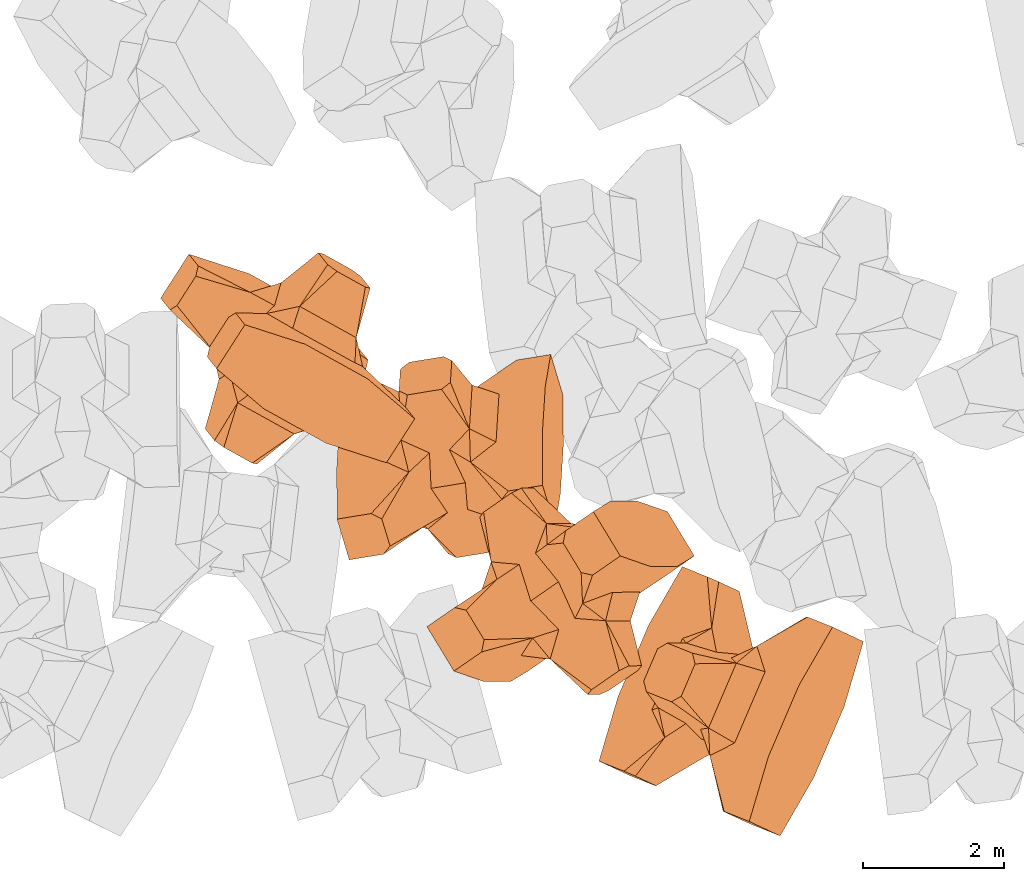
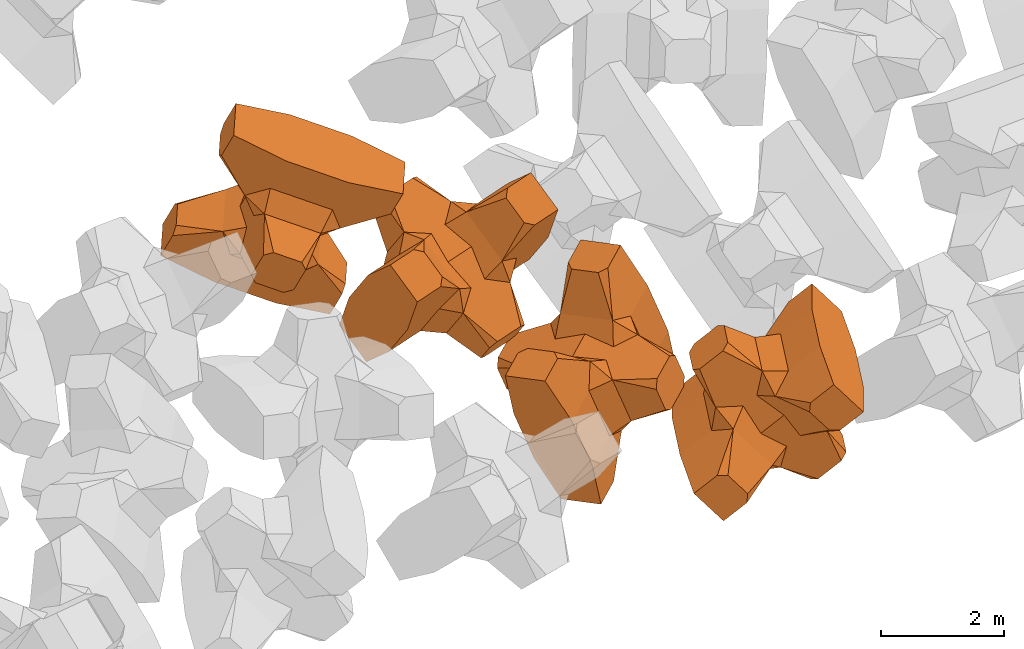
# One storey, part 3 of 17: 4 civil elements.
"""IFC4 building model written with IfcOpenShell, lengths in metres."""

from ifc_helpers import new_model, entity, si_unit, converted_unit, frame, origin_with_axes, origin_2d_with_axis, place, context, subcontext, project, spatial, polygons, element, save


model = new_model("IFC4")

# Units and contexts
model_context = context("Model", 3, precision=1e-05, world=origin_with_axes())
plan_context = context("Plan", 2, precision=1e-05, world=origin_2d_with_axis())
body_context = subcontext(model_context, "Body", "Model", "MODEL_VIEW")
ifc_project = project(units=[si_unit("VOLUMEUNIT", "CUBIC_METRE"), si_unit("LENGTHUNIT", "METRE"), converted_unit("PLANEANGLEUNIT", "degree", entity("IfcReal", 0.0174532925199433), si_unit("PLANEANGLEUNIT", "RADIAN"), dimensions=[0, 0, 0, 0, 0, 0, 0]), si_unit("AREAUNIT", "SQUARE_METRE")], contexts=[model_context, plan_context])

# Site, building, storey
site_placement = place(None, origin_with_axes())
site = spatial("IfcSite", under=ifc_project, at=site_placement)
building_placement = place(site_placement, origin_with_axes())
building = spatial("IfcBuilding", under=site, at=building_placement, Name="Building")
storey_placement = place(building_placement, origin_with_axes())
storey = spatial("IfcBuildingStorey", under=building, at=storey_placement, Name="Storey")

# Civil elements
civil_element_1_placement = place(storey_placement, frame((15.2045488357544, -20.4783554077148, 2.44724321365356), z_axis=(0.583704947890103, -0.272912025201431, -0.764727114929937), x_axis=(0.393692462776794, 0.918833492180181, -0.027409093394634)))
element("IfcCivilElement", 1, at=civil_element_1_placement, inside=storey, ObjectType="IfcCivilElementType", context=body_context, shape_type="Tessellation", body=[
    polygons([(0.500000178813934, 0.500000059604645, 0.821428716182709), (0.374999850988388, 0.249999940395355, 1.50000023841858), (0.550000071525574, 0.145680621266365, 0.550000131130219), (0.374999850988388, -0.250000029802322, 1.50000023841858), (0.651315867900848, -0.250000029802322, 1.45970560083697e-07), (0.651315867900848, 0.249999940395355, 1.45970560083697e-07), (0.550000071525574, -0.145680695772171, 0.550000131130219), (0.500000178813934, -0.500000059604645, 0.821428716182709), (-0.250000029802322, 0.374999791383743, 1.50000023841858), (0.249999985098839, 0.374999791383743, 1.50000023841858), (-0.500000059604645, 0.500000059604645, 0.821428716182709), (-0.550000071525574, 0.824999988079071, 0.550000131130219), (0.550000071525574, 0.824999988079071, 0.550000131130219), (-0.550000071525574, 1.5, 0.550000131130219), (0.550000071525574, 1.5, 0.550000131130219), (-0.250000029802322, -0.375, 1.50000023841858), (0.249999985098839, -0.375, 1.50000023841858), (-0.375, -0.250000029802322, 1.50000023841858), (-0.375, 0.249999940395355, 1.50000023841858), (1.50000023841858, 0.87499988079071, -0.249999836087227), (1.50000023841858, 0.87499988079071, 0.25000011920929), (0.845557630062103, 0.449999898672104, -0.49555516242981), (0.845557630062103, 0.449999898672104, 0.49555516242981), (1.50000023841858, 1.5, -0.374999821186066), (1.50000023841858, 1.5, 0.374999970197678), (1.50000023841858, 1.0, -0.374999821186066), (1.50000023841858, 1.0, 0.374999970197678), (-1.50000023841858, 1.5, -0.374999821186066), (-1.50000023841858, 1.5, 0.374999970197678), (-0.550000071525574, 1.5, -0.549999833106995), (0.550000071525574, 1.5, -0.549999833106995), (0.550000071525574, 0.145680621266365, -0.549999833106995), (-0.500000059604645, -0.500000059604645, 0.821428716182709), (-0.550000071525574, -0.145680695772171, 0.550000131130219), (-0.651315867900848, 0.249999940395355, 1.45970560083697e-07), (-0.651315867900848, -0.250000029802322, 1.45970560083697e-07), (-0.550000071525574, 0.145680621266365, 0.550000131130219), (-1.50000023841858, 0.87499988079071, 0.25000011920929), (-1.50000023841858, 0.87499988079071, -0.249999836087227), (-0.845557451248169, 0.449999898672104, 0.49555516242981), (-0.845557451248169, 0.449999898672104, -0.49555516242981), (-1.50000023841858, 1.0, 0.374999970197678), (-1.50000023841858, 1.0, -0.374999821186066), (-0.550000071525574, 0.145680621266365, -0.549999833106995), (0.550000071525574, -0.825000107288361, 0.550000131130219), (-0.550000071525574, -0.825000107288361, 0.550000131130219), (0.550000071525574, -1.5, 0.550000131130219), (-0.550000071525574, -1.5, 0.550000131130219), (1.50000023841858, -0.875000059604645, 0.25000011920929), (1.50000023841858, -0.875000059604645, -0.249999836087227), (0.845557630062103, -0.450000137090683, 0.49555516242981), (0.845557630062103, -0.450000137090683, -0.49555516242981), (1.50000023841858, -1.5, 0.374999970197678), (1.50000023841858, -1.5, -0.374999821186066), (1.50000023841858, -1.00000011920929, 0.374999970197678), (1.50000023841858, -1.00000011920929, -0.374999821186066), (0.550000071525574, -1.5, -0.549999833106995), (-0.550000071525574, -1.5, -0.549999833106995), (-1.50000023841858, -1.5, -0.374999821186066), (-1.50000023841858, -1.5, 0.374999970197678), (0.550000071525574, -0.145680695772171, -0.549999833106995), (-1.50000023841858, -0.875000059604645, -0.249999836087227), (-1.50000023841858, -0.875000059604645, 0.25000011920929), (-0.845557451248169, -0.450000137090683, -0.49555516242981), (-0.845557451248169, -0.450000137090683, 0.49555516242981), (-1.50000023841858, -1.00000011920929, -0.374999821186066), (-1.50000023841858, -1.00000011920929, 0.374999970197678), (-0.550000071525574, -0.145680695772171, -0.549999833106995), (0.500000178813934, -0.500000059604645, -0.821428537368774), (0.374999850988388, -0.250000029802322, -1.49999988079071), (0.374999850988388, 0.249999940395355, -1.49999988079071), (0.500000178813934, 0.500000059604645, -0.821428537368774), (0.249999985098839, 0.374999791383743, -1.49999988079071), (-0.250000029802322, 0.374999791383743, -1.49999988079071), (-0.500000059604645, 0.500000059604645, -0.821428537368774), (0.550000071525574, 0.824999988079071, -0.549999833106995), (-0.550000071525574, 0.824999988079071, -0.549999833106995), (0.249999985098839, -0.375, -1.49999988079071), (-0.250000029802322, -0.375, -1.49999988079071), (-0.375, -0.250000029802322, -1.49999988079071), (-0.375, 0.249999940395355, -1.49999988079071), (-0.500000059604645, -0.500000059604645, -0.821428537368774), (-0.550000071525574, -0.825000107288361, -0.549999833106995), (0.550000071525574, -0.825000107288361, -0.549999833106995)], [[[1, 2, 3]], [[3, 2, 4]], [[5, 6, 7]], [[7, 6, 3]], [[7, 3, 8]], [[8, 3, 4]], [[9, 10, 11]], [[11, 10, 1]], [[12, 13, 14]], [[14, 13, 15]], [[16, 17, 18]], [[18, 17, 4]], [[18, 4, 19]], [[19, 4, 2]], [[19, 2, 9]], [[9, 2, 10]], [[20, 21, 22]], [[22, 21, 23]], [[24, 25, 26]], [[26, 25, 27]], [[26, 27, 20]], [[20, 27, 21]], [[23, 27, 13]], [[13, 27, 25]], [[13, 25, 15]], [[28, 29, 30]], [[30, 29, 14]], [[30, 14, 31]], [[31, 14, 15]], [[31, 15, 24]], [[24, 15, 25]], [[21, 27, 23]], [[2, 1, 10]], [[13, 12, 1]], [[1, 12, 11]], [[13, 1, 23]], [[32, 22, 6]], [[6, 22, 23]], [[6, 23, 3]], [[3, 23, 1]], [[33, 18, 34]], [[34, 18, 19]], [[35, 36, 37]], [[37, 36, 34]], [[37, 34, 11]], [[11, 34, 19]], [[38, 39, 40]], [[40, 39, 41]], [[29, 28, 42]], [[42, 28, 43]], [[42, 43, 38]], [[38, 43, 39]], [[14, 29, 12]], [[12, 29, 42]], [[12, 42, 40]], [[40, 42, 38]], [[9, 11, 19]], [[40, 11, 12]], [[37, 40, 35]], [[35, 40, 41]], [[35, 41, 44]], [[11, 40, 37]], [[17, 16, 8]], [[8, 16, 33]], [[45, 46, 47]], [[47, 46, 48]], [[49, 50, 51]], [[51, 50, 52]], [[53, 54, 55]], [[55, 54, 56]], [[55, 56, 49]], [[49, 56, 50]], [[47, 53, 45]], [[45, 53, 55]], [[45, 55, 51]], [[54, 53, 57]], [[57, 53, 47]], [[57, 47, 58]], [[58, 47, 48]], [[58, 48, 59]], [[59, 48, 60]], [[51, 55, 49]], [[17, 8, 4]], [[46, 45, 33]], [[33, 45, 8]], [[51, 8, 45]], [[7, 51, 5]], [[5, 51, 52]], [[5, 52, 61]], [[8, 51, 7]], [[62, 63, 64]], [[64, 63, 65]], [[59, 60, 66]], [[66, 60, 67]], [[66, 67, 62]], [[62, 67, 63]], [[65, 67, 46]], [[46, 67, 60]], [[46, 60, 48]], [[63, 67, 65]], [[18, 33, 16]], [[46, 33, 65]], [[68, 64, 36]], [[36, 64, 65]], [[36, 65, 34]], [[34, 65, 33]], [[69, 70, 61]], [[61, 70, 71]], [[6, 5, 32]], [[32, 5, 61]], [[32, 61, 72]], [[72, 61, 71]], [[73, 74, 72]], [[72, 74, 75]], [[76, 77, 31]], [[31, 77, 30]], [[78, 79, 70]], [[70, 79, 80]], [[70, 80, 71]], [[71, 80, 81]], [[71, 81, 73]], [[73, 81, 74]], [[31, 24, 76]], [[76, 24, 26]], [[76, 26, 22]], [[22, 26, 20]], [[73, 72, 71]], [[77, 76, 75]], [[75, 76, 72]], [[22, 72, 76]], [[72, 22, 32]], [[75, 81, 44]], [[44, 81, 80]], [[36, 35, 68]], [[68, 35, 44]], [[68, 44, 82]], [[82, 44, 80]], [[41, 43, 77]], [[77, 43, 28]], [[77, 28, 30]], [[39, 43, 41]], [[81, 75, 74]], [[77, 75, 41]], [[44, 41, 75]], [[79, 78, 82]], [[82, 78, 69]], [[83, 84, 58]], [[58, 84, 57]], [[52, 56, 84]], [[84, 56, 54]], [[84, 54, 57]], [[50, 56, 52]], [[70, 69, 78]], [[84, 83, 69]], [[69, 83, 82]], [[84, 69, 52]], [[61, 52, 69]], [[58, 59, 83]], [[83, 59, 66]], [[83, 66, 64]], [[64, 66, 62]], [[79, 82, 80]], [[64, 82, 83]], [[82, 64, 68]]], closed=True),
])
civil_element_2_placement = place(storey_placement, frame((12.7876129150391, -18.9191856384277, 2.94830465316772), z_axis=(-0.509664130128306, 0.839065154014907, -0.190294881114804), x_axis=(-0.349996678864245, -0.000145226728593835, 0.936750929379414)))
element("IfcCivilElement", 2, at=civil_element_2_placement, inside=storey, ObjectType="IfcCivilElementType", context=body_context, shape_type="Tessellation", body=[
    polygons([(0.500000178813934, 0.50000011920929, 0.821428656578064), (0.374999850988388, 0.249999970197678, 1.5), (0.550000071525574, 0.145680636167526, 0.550000071525574), (0.374999850988388, -0.250000029802322, 1.5), (0.651315867900848, -0.250000029802322, 1.45970545872842e-07), (0.651315867900848, 0.249999970197678, 1.45970545872842e-07), (0.550000071525574, -0.145680710673332, 0.550000071525574), (0.500000178813934, -0.50000011920929, 0.821428656578064), (-0.250000029802322, 0.374999821186066, 1.5), (0.249999985098839, 0.374999821186066, 1.5), (-0.500000059604645, 0.50000011920929, 0.821428656578064), (-0.550000071525574, 0.825000047683716, 0.550000071525574), (0.550000071525574, 0.825000047683716, 0.550000071525574), (-0.550000071525574, 1.50000023841858, 0.550000071525574), (0.550000071525574, 1.50000023841858, 0.550000071525574), (-0.250000029802322, -0.375000059604645, 1.5), (0.249999985098839, -0.375000059604645, 1.5), (-0.375, -0.250000029802322, 1.5), (-0.375, 0.249999970197678, 1.5), (1.50000023841858, 0.874999940395355, -0.249999806284904), (1.50000023841858, 0.874999940395355, 0.25000011920929), (0.845557630062103, 0.449999958276749, -0.495555102825165), (0.845557630062103, 0.449999958276749, 0.495555102825165), (1.50000023841858, 1.50000023841858, -0.374999791383743), (1.50000023841858, 1.50000023841858, 0.374999940395355), (1.50000023841858, 1.00000011920929, -0.374999791383743), (1.50000023841858, 1.00000011920929, 0.374999940395355), (-1.50000023841858, 1.50000023841858, -0.374999791383743), (-1.50000023841858, 1.50000023841858, 0.374999940395355), (-0.550000071525574, 1.50000023841858, -0.54999977350235), (0.550000071525574, 1.50000023841858, -0.54999977350235), (0.550000071525574, 0.145680636167526, -0.54999977350235), (-0.500000059604645, -0.50000011920929, 0.821428656578064), (-0.550000071525574, -0.145680710673332, 0.550000071525574), (-0.651315867900848, 0.249999970197678, 1.45970545872842e-07), (-0.651315867900848, -0.250000029802322, 1.45970545872842e-07), (-0.550000071525574, 0.145680636167526, 0.550000071525574), (-1.50000023841858, 0.874999940395355, 0.25000011920929), (-1.50000023841858, 0.874999940395355, -0.249999806284904), (-0.845557451248169, 0.449999958276749, 0.495555102825165), (-0.845557451248169, 0.449999958276749, -0.495555102825165), (-1.50000023841858, 1.00000011920929, 0.374999940395355), (-1.50000023841858, 1.00000011920929, -0.374999791383743), (-0.550000071525574, 0.145680636167526, -0.54999977350235), (0.550000071525574, -0.82500022649765, 0.550000071525574), (-0.550000071525574, -0.82500022649765, 0.550000071525574), (0.550000071525574, -1.50000023841858, 0.550000071525574), (-0.550000071525574, -1.50000023841858, 0.550000071525574), (1.50000023841858, -0.875000178813934, 0.25000011920929), (1.50000023841858, -0.875000178813934, -0.249999806284904), (0.845557630062103, -0.450000166893005, 0.495555102825165), (0.845557630062103, -0.450000166893005, -0.495555102825165), (1.50000023841858, -1.50000023841858, 0.374999940395355), (1.50000023841858, -1.50000023841858, -0.374999791383743), (1.50000023841858, -1.00000023841858, 0.374999940395355), (1.50000023841858, -1.00000023841858, -0.374999791383743), (0.550000071525574, -1.50000023841858, -0.54999977350235), (-0.550000071525574, -1.50000023841858, -0.54999977350235), (-1.50000023841858, -1.50000023841858, -0.374999791383743), (-1.50000023841858, -1.50000023841858, 0.374999940395355), (0.550000071525574, -0.145680710673332, -0.54999977350235), (-1.50000023841858, -0.875000178813934, -0.249999806284904), (-1.50000023841858, -0.875000178813934, 0.25000011920929), (-0.845557451248169, -0.450000166893005, -0.495555102825165), (-0.845557451248169, -0.450000166893005, 0.495555102825165), (-1.50000023841858, -1.00000023841858, -0.374999791383743), (-1.50000023841858, -1.00000023841858, 0.374999940395355), (-0.550000071525574, -0.145680710673332, -0.54999977350235), (0.500000178813934, -0.50000011920929, -0.821428418159485), (0.374999850988388, -0.250000029802322, -1.49999976158142), (0.374999850988388, 0.249999970197678, -1.49999976158142), (0.500000178813934, 0.50000011920929, -0.821428418159485), (0.249999985098839, 0.374999821186066, -1.49999976158142), (-0.250000029802322, 0.374999821186066, -1.49999976158142), (-0.500000059604645, 0.50000011920929, -0.821428418159485), (0.550000071525574, 0.825000047683716, -0.54999977350235), (-0.550000071525574, 0.825000047683716, -0.54999977350235), (0.249999985098839, -0.375000059604645, -1.49999976158142), (-0.250000029802322, -0.375000059604645, -1.49999976158142), (-0.375, -0.250000029802322, -1.49999976158142), (-0.375, 0.249999970197678, -1.49999976158142), (-0.500000059604645, -0.50000011920929, -0.821428418159485), (-0.550000071525574, -0.82500022649765, -0.54999977350235), (0.550000071525574, -0.82500022649765, -0.54999977350235)], [[[1, 2, 3]], [[3, 2, 4]], [[5, 6, 7]], [[7, 6, 3]], [[7, 3, 8]], [[8, 3, 4]], [[9, 10, 11]], [[11, 10, 1]], [[12, 13, 14]], [[14, 13, 15]], [[16, 17, 18]], [[18, 17, 4]], [[18, 4, 19]], [[19, 4, 2]], [[19, 2, 9]], [[9, 2, 10]], [[20, 21, 22]], [[22, 21, 23]], [[24, 25, 26]], [[26, 25, 27]], [[26, 27, 20]], [[20, 27, 21]], [[23, 27, 13]], [[13, 27, 25]], [[13, 25, 15]], [[28, 29, 30]], [[30, 29, 14]], [[30, 14, 31]], [[31, 14, 15]], [[31, 15, 24]], [[24, 15, 25]], [[21, 27, 23]], [[2, 1, 10]], [[13, 12, 1]], [[1, 12, 11]], [[13, 1, 23]], [[32, 22, 6]], [[6, 22, 23]], [[6, 23, 3]], [[3, 23, 1]], [[33, 18, 34]], [[34, 18, 19]], [[35, 36, 37]], [[37, 36, 34]], [[37, 34, 11]], [[11, 34, 19]], [[38, 39, 40]], [[40, 39, 41]], [[29, 28, 42]], [[42, 28, 43]], [[42, 43, 38]], [[38, 43, 39]], [[14, 29, 12]], [[12, 29, 42]], [[12, 42, 40]], [[40, 42, 38]], [[9, 11, 19]], [[40, 11, 12]], [[37, 40, 35]], [[35, 40, 41]], [[35, 41, 44]], [[11, 40, 37]], [[17, 16, 8]], [[8, 16, 33]], [[45, 46, 47]], [[47, 46, 48]], [[49, 50, 51]], [[51, 50, 52]], [[53, 54, 55]], [[55, 54, 56]], [[55, 56, 49]], [[49, 56, 50]], [[47, 53, 45]], [[45, 53, 55]], [[45, 55, 51]], [[54, 53, 57]], [[57, 53, 47]], [[57, 47, 58]], [[58, 47, 48]], [[58, 48, 59]], [[59, 48, 60]], [[51, 55, 49]], [[17, 8, 4]], [[46, 45, 33]], [[33, 45, 8]], [[51, 8, 45]], [[7, 51, 5]], [[5, 51, 52]], [[5, 52, 61]], [[8, 51, 7]], [[62, 63, 64]], [[64, 63, 65]], [[59, 60, 66]], [[66, 60, 67]], [[66, 67, 62]], [[62, 67, 63]], [[65, 67, 46]], [[46, 67, 60]], [[46, 60, 48]], [[63, 67, 65]], [[18, 33, 16]], [[46, 33, 65]], [[68, 64, 36]], [[36, 64, 65]], [[36, 65, 34]], [[34, 65, 33]], [[69, 70, 61]], [[61, 70, 71]], [[6, 5, 32]], [[32, 5, 61]], [[32, 61, 72]], [[72, 61, 71]], [[73, 74, 72]], [[72, 74, 75]], [[76, 77, 31]], [[31, 77, 30]], [[78, 79, 70]], [[70, 79, 80]], [[70, 80, 71]], [[71, 80, 81]], [[71, 81, 73]], [[73, 81, 74]], [[31, 24, 76]], [[76, 24, 26]], [[76, 26, 22]], [[22, 26, 20]], [[73, 72, 71]], [[77, 76, 75]], [[75, 76, 72]], [[22, 72, 76]], [[72, 22, 32]], [[75, 81, 44]], [[44, 81, 80]], [[36, 35, 68]], [[68, 35, 44]], [[68, 44, 82]], [[82, 44, 80]], [[41, 43, 77]], [[77, 43, 28]], [[77, 28, 30]], [[39, 43, 41]], [[81, 75, 74]], [[77, 75, 41]], [[44, 41, 75]], [[79, 78, 82]], [[82, 78, 69]], [[83, 84, 58]], [[58, 84, 57]], [[52, 56, 84]], [[84, 56, 54]], [[84, 54, 57]], [[50, 56, 52]], [[70, 69, 78]], [[84, 83, 69]], [[69, 83, 82]], [[84, 69, 52]], [[61, 52, 69]], [[58, 59, 83]], [[83, 59, 66]], [[83, 66, 64]], [[64, 66, 62]], [[79, 82, 80]], [[64, 82, 83]], [[82, 64, 68]]], closed=True),
])
civil_element_3_placement = place(storey_placement, frame((11.2182750701904, -17.0171203613281, 4.42178297042847), z_axis=(-0.23247782988193, 0.769391361279879, 0.594971420995398), x_axis=(-0.03830822547359, -0.618500648338416, 0.78484993971206)))
element("IfcCivilElement", 3, at=civil_element_3_placement, inside=storey, ObjectType="IfcCivilElementType", context=body_context, shape_type="Tessellation", body=[
    polygons([(0.500000059604645, 0.500000059604645, 0.821428656578064), (0.374999791383743, 0.249999940395355, 1.5), (0.549999952316284, 0.145680621266365, 0.550000071525574), (0.374999791383743, -0.250000029802322, 1.5), (0.651315748691559, -0.250000029802322, 1.45970545872842e-07), (0.651315748691559, 0.249999940395355, 1.45970545872842e-07), (0.549999952316284, -0.145680695772171, 0.550000071525574), (0.500000059604645, -0.500000059604645, 0.821428656578064), (-0.249999970197678, 0.374999791383743, 1.5), (0.249999940395355, 0.374999791383743, 1.5), (-0.5, 0.500000059604645, 0.821428656578064), (-0.549999952316284, 0.824999988079071, 0.550000071525574), (0.549999952316284, 0.824999988079071, 0.550000071525574), (-0.549999952316284, 1.5, 0.550000071525574), (0.549999952316284, 1.5, 0.550000071525574), (-0.249999970197678, -0.375, 1.5), (0.249999940395355, -0.375, 1.5), (-0.374999940395355, -0.250000029802322, 1.5), (-0.374999940395355, 0.249999940395355, 1.5), (1.49999988079071, 0.87499988079071, -0.249999806284904), (1.49999988079071, 0.87499988079071, 0.25000011920929), (0.845557451248169, 0.449999898672104, -0.495555102825165), (0.845557451248169, 0.449999898672104, 0.495555102825165), (1.49999988079071, 1.5, -0.374999791383743), (1.49999988079071, 1.5, 0.374999940395355), (1.49999988079071, 1.0, -0.374999791383743), (1.49999988079071, 1.0, 0.374999940395355), (-1.49999988079071, 1.5, -0.374999791383743), (-1.49999988079071, 1.5, 0.374999940395355), (-0.549999952316284, 1.5, -0.54999977350235), (0.549999952316284, 1.5, -0.54999977350235), (0.549999952316284, 0.145680621266365, -0.54999977350235), (-0.5, -0.500000059604645, 0.821428656578064), (-0.549999952316284, -0.145680695772171, 0.550000071525574), (-0.651315748691559, 0.249999940395355, 1.45970545872842e-07), (-0.651315748691559, -0.250000029802322, 1.45970545872842e-07), (-0.549999952316284, 0.145680621266365, 0.550000071525574), (-1.49999988079071, 0.87499988079071, 0.25000011920929), (-1.49999988079071, 0.87499988079071, -0.249999806284904), (-0.845557332038879, 0.449999898672104, 0.495555102825165), (-0.845557332038879, 0.449999898672104, -0.495555102825165), (-1.49999988079071, 1.0, 0.374999940395355), (-1.49999988079071, 1.0, -0.374999791383743), (-0.549999952316284, 0.145680621266365, -0.54999977350235), (0.549999952316284, -0.825000107288361, 0.550000071525574), (-0.549999952316284, -0.825000107288361, 0.550000071525574), (0.549999952316284, -1.5, 0.550000071525574), (-0.549999952316284, -1.5, 0.550000071525574), (1.49999988079071, -0.875000059604645, 0.25000011920929), (1.49999988079071, -0.875000059604645, -0.249999806284904), (0.845557451248169, -0.450000137090683, 0.495555102825165), (0.845557451248169, -0.450000137090683, -0.495555102825165), (1.49999988079071, -1.5, 0.374999940395355), (1.49999988079071, -1.5, -0.374999791383743), (1.49999988079071, -1.00000011920929, 0.374999940395355), (1.49999988079071, -1.00000011920929, -0.374999791383743), (0.549999952316284, -1.5, -0.54999977350235), (-0.549999952316284, -1.5, -0.54999977350235), (-1.49999988079071, -1.5, -0.374999791383743), (-1.49999988079071, -1.5, 0.374999940395355), (0.549999952316284, -0.145680695772171, -0.54999977350235), (-1.49999988079071, -0.875000059604645, -0.249999806284904), (-1.49999988079071, -0.875000059604645, 0.25000011920929), (-0.845557332038879, -0.450000137090683, -0.495555102825165), (-0.845557332038879, -0.450000137090683, 0.495555102825165), (-1.49999988079071, -1.00000011920929, -0.374999791383743), (-1.49999988079071, -1.00000011920929, 0.374999940395355), (-0.549999952316284, -0.145680695772171, -0.54999977350235), (0.500000059604645, -0.500000059604645, -0.821428418159485), (0.374999791383743, -0.250000029802322, -1.49999976158142), (0.374999791383743, 0.249999940395355, -1.49999976158142), (0.500000059604645, 0.500000059604645, -0.821428418159485), (0.249999940395355, 0.374999791383743, -1.49999976158142), (-0.249999970197678, 0.374999791383743, -1.49999976158142), (-0.5, 0.500000059604645, -0.821428418159485), (0.549999952316284, 0.824999988079071, -0.54999977350235), (-0.549999952316284, 0.824999988079071, -0.54999977350235), (0.249999940395355, -0.375, -1.49999976158142), (-0.249999970197678, -0.375, -1.49999976158142), (-0.374999940395355, -0.250000029802322, -1.49999976158142), (-0.374999940395355, 0.249999940395355, -1.49999976158142), (-0.5, -0.500000059604645, -0.821428418159485), (-0.549999952316284, -0.825000107288361, -0.54999977350235), (0.549999952316284, -0.825000107288361, -0.54999977350235)], [[[1, 2, 3]], [[3, 2, 4]], [[5, 6, 7]], [[7, 6, 3]], [[7, 3, 8]], [[8, 3, 4]], [[9, 10, 11]], [[11, 10, 1]], [[12, 13, 14]], [[14, 13, 15]], [[16, 17, 18]], [[18, 17, 4]], [[18, 4, 19]], [[19, 4, 2]], [[19, 2, 9]], [[9, 2, 10]], [[20, 21, 22]], [[22, 21, 23]], [[24, 25, 26]], [[26, 25, 27]], [[26, 27, 20]], [[20, 27, 21]], [[23, 27, 13]], [[13, 27, 25]], [[13, 25, 15]], [[28, 29, 30]], [[30, 29, 14]], [[30, 14, 31]], [[31, 14, 15]], [[31, 15, 24]], [[24, 15, 25]], [[21, 27, 23]], [[2, 1, 10]], [[13, 12, 1]], [[1, 12, 11]], [[13, 1, 23]], [[32, 22, 6]], [[6, 22, 23]], [[6, 23, 3]], [[3, 23, 1]], [[33, 18, 34]], [[34, 18, 19]], [[35, 36, 37]], [[37, 36, 34]], [[37, 34, 11]], [[11, 34, 19]], [[38, 39, 40]], [[40, 39, 41]], [[29, 28, 42]], [[42, 28, 43]], [[42, 43, 38]], [[38, 43, 39]], [[14, 29, 12]], [[12, 29, 42]], [[12, 42, 40]], [[40, 42, 38]], [[9, 11, 19]], [[40, 11, 12]], [[37, 40, 35]], [[35, 40, 41]], [[35, 41, 44]], [[11, 40, 37]], [[17, 16, 8]], [[8, 16, 33]], [[45, 46, 47]], [[47, 46, 48]], [[49, 50, 51]], [[51, 50, 52]], [[53, 54, 55]], [[55, 54, 56]], [[55, 56, 49]], [[49, 56, 50]], [[47, 53, 45]], [[45, 53, 55]], [[45, 55, 51]], [[54, 53, 57]], [[57, 53, 47]], [[57, 47, 58]], [[58, 47, 48]], [[58, 48, 59]], [[59, 48, 60]], [[51, 55, 49]], [[17, 8, 4]], [[46, 45, 33]], [[33, 45, 8]], [[51, 8, 45]], [[7, 51, 5]], [[5, 51, 52]], [[5, 52, 61]], [[8, 51, 7]], [[62, 63, 64]], [[64, 63, 65]], [[59, 60, 66]], [[66, 60, 67]], [[66, 67, 62]], [[62, 67, 63]], [[65, 67, 46]], [[46, 67, 60]], [[46, 60, 48]], [[63, 67, 65]], [[18, 33, 16]], [[46, 33, 65]], [[68, 64, 36]], [[36, 64, 65]], [[36, 65, 34]], [[34, 65, 33]], [[69, 70, 61]], [[61, 70, 71]], [[6, 5, 32]], [[32, 5, 61]], [[32, 61, 72]], [[72, 61, 71]], [[73, 74, 72]], [[72, 74, 75]], [[76, 77, 31]], [[31, 77, 30]], [[78, 79, 70]], [[70, 79, 80]], [[70, 80, 71]], [[71, 80, 81]], [[71, 81, 73]], [[73, 81, 74]], [[31, 24, 76]], [[76, 24, 26]], [[76, 26, 22]], [[22, 26, 20]], [[73, 72, 71]], [[77, 76, 75]], [[75, 76, 72]], [[22, 72, 76]], [[72, 22, 32]], [[75, 81, 44]], [[44, 81, 80]], [[36, 35, 68]], [[68, 35, 44]], [[68, 44, 82]], [[82, 44, 80]], [[41, 43, 77]], [[77, 43, 28]], [[77, 28, 30]], [[39, 43, 41]], [[81, 75, 74]], [[77, 75, 41]], [[44, 41, 75]], [[79, 78, 82]], [[82, 78, 69]], [[83, 84, 58]], [[58, 84, 57]], [[52, 56, 84]], [[84, 56, 54]], [[84, 54, 57]], [[50, 56, 52]], [[70, 69, 78]], [[84, 83, 69]], [[69, 83, 82]], [[84, 69, 52]], [[61, 52, 69]], [[58, 59, 83]], [[83, 59, 66]], [[83, 66, 64]], [[64, 66, 62]], [[79, 82, 80]], [[64, 82, 83]], [[82, 64, 68]]], closed=True),
])
civil_element_4_placement = place(storey_placement, frame((8.91715145111084, -15.617862701416, 5.53763198852539), z_axis=(0.534912471805963, 0.831514008358983, 0.149843589816891), x_axis=(-0.802354231988513, 0.444346078825315, 0.398477412964262)))
element("IfcCivilElement", 4, at=civil_element_4_placement, inside=storey, ObjectType="IfcCivilElementType", context=body_context, shape_type="Tessellation", body=[
    polygons([(0.499999523162842, 0.50000011920929, 0.821428716182709), (0.374999403953552, 0.249999970197678, 1.50000023841858), (0.549999356269836, 0.145680636167526, 0.550000131130219), (0.374999403953552, -0.250000029802322, 1.50000023841858), (0.651315033435822, -0.250000029802322, 1.45970560083697e-07), (0.651315033435822, 0.249999970197678, 1.45970560083697e-07), (0.549999356269836, -0.145680710673332, 0.550000131130219), (0.499999523162842, -0.50000011920929, 0.821428716182709), (-0.249999701976776, 0.374999821186066, 1.50000023841858), (0.249999672174454, 0.374999821186066, 1.50000023841858), (-0.499999463558197, 0.50000011920929, 0.821428716182709), (-0.549999356269836, 0.825000047683716, 0.550000131130219), (0.549999356269836, 0.825000047683716, 0.550000131130219), (-0.549999356269836, 1.50000023841858, 0.550000131130219), (0.549999356269836, 1.50000023841858, 0.550000131130219), (-0.249999701976776, -0.375000059604645, 1.50000023841858), (0.249999672174454, -0.375000059604645, 1.50000023841858), (-0.374999523162842, -0.250000029802322, 1.50000023841858), (-0.374999523162842, 0.249999970197678, 1.50000023841858), (1.49999833106995, 0.874999940395355, -0.249999836087227), (1.49999833106995, 0.874999940395355, 0.25000011920929), (0.845556557178497, 0.449999958276749, -0.49555516242981), (0.845556557178497, 0.449999958276749, 0.49555516242981), (1.49999833106995, 1.50000023841858, -0.374999821186066), (1.49999833106995, 1.50000023841858, 0.374999970197678), (1.49999833106995, 1.00000011920929, -0.374999821186066), (1.49999833106995, 1.00000011920929, 0.374999970197678), (-1.49999833106995, 1.50000023841858, -0.374999821186066), (-1.49999833106995, 1.50000023841858, 0.374999970197678), (-0.549999356269836, 1.50000023841858, -0.549999833106995), (0.549999356269836, 1.50000023841858, -0.549999833106995), (0.549999356269836, 0.145680636167526, -0.549999833106995), (-0.499999463558197, -0.50000011920929, 0.821428716182709), (-0.549999356269836, -0.145680710673332, 0.550000131130219), (-0.651315033435822, 0.249999970197678, 1.45970560083697e-07), (-0.651315033435822, -0.250000029802322, 1.45970560083697e-07), (-0.549999356269836, 0.145680636167526, 0.550000131130219), (-1.49999833106995, 0.874999940395355, 0.25000011920929), (-1.49999833106995, 0.874999940395355, -0.249999836087227), (-0.845556378364563, 0.449999958276749, 0.49555516242981), (-0.845556378364563, 0.449999958276749, -0.49555516242981), (-1.49999833106995, 1.00000011920929, 0.374999970197678), (-1.49999833106995, 1.00000011920929, -0.374999821186066), (-0.549999356269836, 0.145680636167526, -0.549999833106995), (0.549999356269836, -0.82500022649765, 0.550000131130219), (-0.549999356269836, -0.82500022649765, 0.550000131130219), (0.549999356269836, -1.50000023841858, 0.550000131130219), (-0.549999356269836, -1.50000023841858, 0.550000131130219), (1.49999833106995, -0.875000178813934, 0.25000011920929), (1.49999833106995, -0.875000178813934, -0.249999836087227), (0.845556557178497, -0.450000166893005, 0.49555516242981), (0.845556557178497, -0.450000166893005, -0.49555516242981), (1.49999833106995, -1.50000023841858, 0.374999970197678), (1.49999833106995, -1.50000023841858, -0.374999821186066), (1.49999833106995, -1.00000023841858, 0.374999970197678), (1.49999833106995, -1.00000023841858, -0.374999821186066), (0.549999356269836, -1.50000023841858, -0.549999833106995), (-0.549999356269836, -1.50000023841858, -0.549999833106995), (-1.49999833106995, -1.50000023841858, -0.374999821186066), (-1.49999833106995, -1.50000023841858, 0.374999970197678), (0.549999356269836, -0.145680710673332, -0.549999833106995), (-1.49999833106995, -0.875000178813934, -0.249999836087227), (-1.49999833106995, -0.875000178813934, 0.25000011920929), (-0.845556378364563, -0.450000166893005, -0.49555516242981), (-0.845556378364563, -0.450000166893005, 0.49555516242981), (-1.49999833106995, -1.00000023841858, -0.374999821186066), (-1.49999833106995, -1.00000023841858, 0.374999970197678), (-0.549999356269836, -0.145680710673332, -0.549999833106995), (0.499999523162842, -0.50000011920929, -0.821428537368774), (0.374999403953552, -0.250000029802322, -1.49999988079071), (0.374999403953552, 0.249999970197678, -1.49999988079071), (0.499999523162842, 0.50000011920929, -0.821428537368774), (0.249999672174454, 0.374999821186066, -1.49999988079071), (-0.249999701976776, 0.374999821186066, -1.49999988079071), (-0.499999463558197, 0.50000011920929, -0.821428537368774), (0.549999356269836, 0.825000047683716, -0.549999833106995), (-0.549999356269836, 0.825000047683716, -0.549999833106995), (0.249999672174454, -0.375000059604645, -1.49999988079071), (-0.249999701976776, -0.375000059604645, -1.49999988079071), (-0.374999523162842, -0.250000029802322, -1.49999988079071), (-0.374999523162842, 0.249999970197678, -1.49999988079071), (-0.499999463558197, -0.50000011920929, -0.821428537368774), (-0.549999356269836, -0.82500022649765, -0.549999833106995), (0.549999356269836, -0.82500022649765, -0.549999833106995)], [[[1, 2, 3]], [[3, 2, 4]], [[5, 6, 7]], [[7, 6, 3]], [[7, 3, 8]], [[8, 3, 4]], [[9, 10, 11]], [[11, 10, 1]], [[12, 13, 14]], [[14, 13, 15]], [[16, 17, 18]], [[18, 17, 4]], [[18, 4, 19]], [[19, 4, 2]], [[19, 2, 9]], [[9, 2, 10]], [[20, 21, 22]], [[22, 21, 23]], [[24, 25, 26]], [[26, 25, 27]], [[26, 27, 20]], [[20, 27, 21]], [[23, 27, 13]], [[13, 27, 25]], [[13, 25, 15]], [[28, 29, 30]], [[30, 29, 14]], [[30, 14, 31]], [[31, 14, 15]], [[31, 15, 24]], [[24, 15, 25]], [[21, 27, 23]], [[2, 1, 10]], [[13, 12, 1]], [[1, 12, 11]], [[13, 1, 23]], [[32, 22, 6]], [[6, 22, 23]], [[6, 23, 3]], [[3, 23, 1]], [[33, 18, 34]], [[34, 18, 19]], [[35, 36, 37]], [[37, 36, 34]], [[37, 34, 11]], [[11, 34, 19]], [[38, 39, 40]], [[40, 39, 41]], [[29, 28, 42]], [[42, 28, 43]], [[42, 43, 38]], [[38, 43, 39]], [[14, 29, 12]], [[12, 29, 42]], [[12, 42, 40]], [[40, 42, 38]], [[9, 11, 19]], [[40, 11, 12]], [[37, 40, 35]], [[35, 40, 41]], [[35, 41, 44]], [[11, 40, 37]], [[17, 16, 8]], [[8, 16, 33]], [[45, 46, 47]], [[47, 46, 48]], [[49, 50, 51]], [[51, 50, 52]], [[53, 54, 55]], [[55, 54, 56]], [[55, 56, 49]], [[49, 56, 50]], [[47, 53, 45]], [[45, 53, 55]], [[45, 55, 51]], [[54, 53, 57]], [[57, 53, 47]], [[57, 47, 58]], [[58, 47, 48]], [[58, 48, 59]], [[59, 48, 60]], [[51, 55, 49]], [[17, 8, 4]], [[46, 45, 33]], [[33, 45, 8]], [[51, 8, 45]], [[7, 51, 5]], [[5, 51, 52]], [[5, 52, 61]], [[8, 51, 7]], [[62, 63, 64]], [[64, 63, 65]], [[59, 60, 66]], [[66, 60, 67]], [[66, 67, 62]], [[62, 67, 63]], [[65, 67, 46]], [[46, 67, 60]], [[46, 60, 48]], [[63, 67, 65]], [[18, 33, 16]], [[46, 33, 65]], [[68, 64, 36]], [[36, 64, 65]], [[36, 65, 34]], [[34, 65, 33]], [[69, 70, 61]], [[61, 70, 71]], [[6, 5, 32]], [[32, 5, 61]], [[32, 61, 72]], [[72, 61, 71]], [[73, 74, 72]], [[72, 74, 75]], [[76, 77, 31]], [[31, 77, 30]], [[78, 79, 70]], [[70, 79, 80]], [[70, 80, 71]], [[71, 80, 81]], [[71, 81, 73]], [[73, 81, 74]], [[31, 24, 76]], [[76, 24, 26]], [[76, 26, 22]], [[22, 26, 20]], [[73, 72, 71]], [[77, 76, 75]], [[75, 76, 72]], [[22, 72, 76]], [[72, 22, 32]], [[75, 81, 44]], [[44, 81, 80]], [[36, 35, 68]], [[68, 35, 44]], [[68, 44, 82]], [[82, 44, 80]], [[41, 43, 77]], [[77, 43, 28]], [[77, 28, 30]], [[39, 43, 41]], [[81, 75, 74]], [[77, 75, 41]], [[44, 41, 75]], [[79, 78, 82]], [[82, 78, 69]], [[83, 84, 58]], [[58, 84, 57]], [[52, 56, 84]], [[84, 56, 54]], [[84, 54, 57]], [[50, 56, 52]], [[70, 69, 78]], [[84, 83, 69]], [[69, 83, 82]], [[84, 69, 52]], [[61, 52, 69]], [[58, 59, 83]], [[83, 59, 66]], [[83, 66, 64]], [[64, 66, 62]], [[79, 82, 80]], [[64, 82, 83]], [[82, 64, 68]]], closed=True),
])

save(model, "model.ifc")
